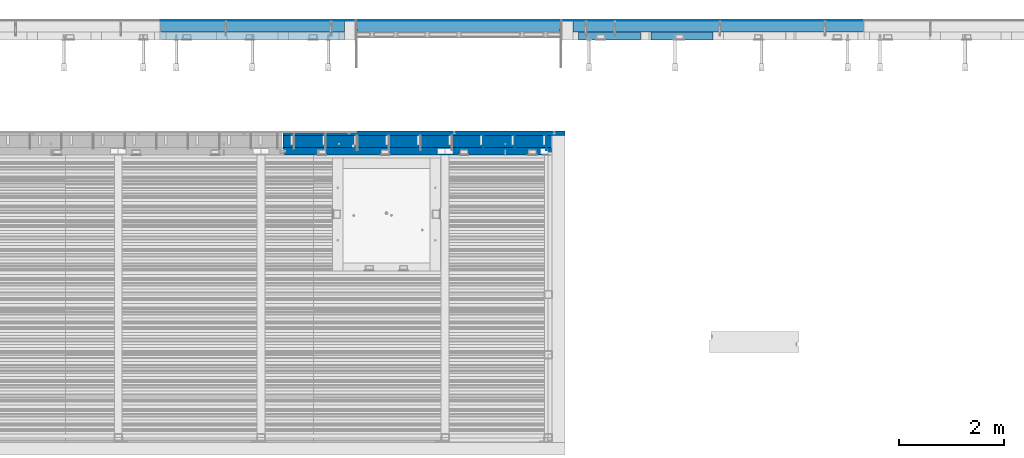
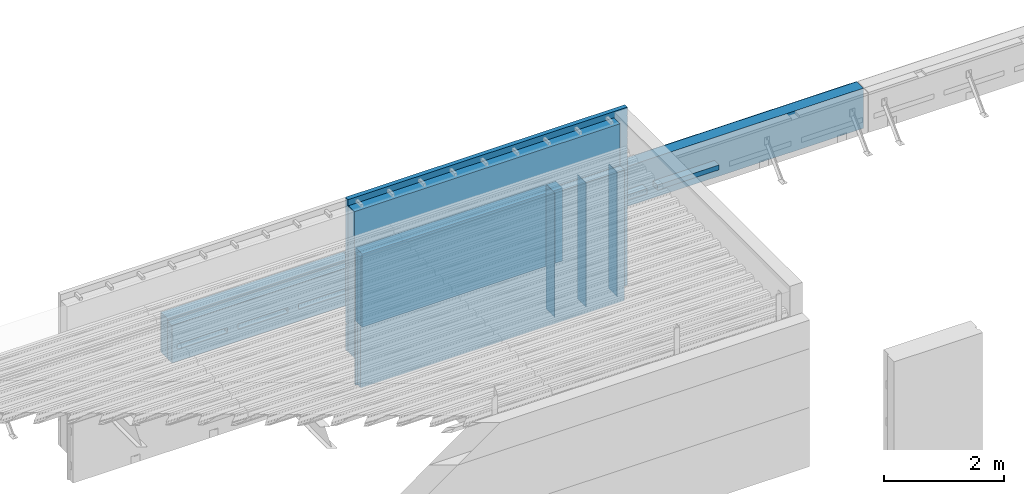
# One storey, part 80 of 153: 15 walls, 7 elements without a shape of their own.
"""IFC2X3 building model written with IfcOpenShell, lengths in millimetres."""

from ifc_helpers import new_model, si_unit, frame, origin_with_axes, place, context, subcontext, project, spatial, faceted_brep, material, type_object, element, aggregate, save


model = new_model("IFC2X3")

# Units and contexts
model_context = context("Model", 3, precision=1e-05, world=origin_with_axes())
body_context = subcontext(model_context, "Body", "Model", "MODEL_VIEW")
ifc_project = project(units=[si_unit("LENGTHUNIT", "METRE", prefix="MILLI"), si_unit("AREAUNIT", "SQUARE_METRE"), si_unit("VOLUMEUNIT", "CUBIC_METRE"), si_unit("MASSUNIT", "GRAM", prefix="KILO"), si_unit("TIMEUNIT", "SECOND"), si_unit("PLANEANGLEUNIT", "RADIAN"), si_unit("SOLIDANGLEUNIT", "STERADIAN"), si_unit("THERMODYNAMICTEMPERATUREUNIT", "DEGREE_CELSIUS"), si_unit("LUMINOUSINTENSITYUNIT", "LUMEN")], contexts=[model_context])

# Site, building, storey
site_placement = place(None, origin_with_axes())
site = spatial("IfcSite", under=ifc_project, at=site_placement, CompositionType="ELEMENT")
building_placement = place(site_placement, origin_with_axes())
building = spatial("IfcBuilding", under=site, at=building_placement, CompositionType="ELEMENT")
storey_placement = place(building_placement, origin_with_axes())
storey = spatial("IfcBuildingStorey", under=building, at=storey_placement, Name="8", CompositionType="ELEMENT", Elevation=0.0)

# Assembly, walls
assembly_1_placement = place(storey_placement, origin_with_axes())
assembly_1 = element("IfcElementAssembly", 1, at=assembly_1_placement, inside=storey, AssemblyPlace="NOTDEFINED", PredefinedType="REINFORCEMENT_UNIT")
ifc_material_1 = material(Name="Undefined")
wall_type_1 = type_object("IfcWallType", PredefinedType="NOTDEFINED")
wall_1_placement = place(assembly_1_placement, frame((21680.0500042038, 20799.9500000001, 104075.0), z_axis=(0.0, 0.0, 1.0), x_axis=(0.0, -1.0, 0.0)))
wall_1 = element("IfcWall", 2, at=wall_1_placement, type_object=wall_type_1, material=ifc_material_1, Name="(PD)", context=body_context, shape_type="Brep", body=[
    faceted_brep([(0.0, 5.0, -1265.0), (0.0, 5.0, 1265.0), (280.000000000011, 5.0, 1265.0), (280.000000000011, 5.0, -1265.0), (0.0, -5.0, 1265.0), (280.000000000011, -5.0, 1265.0), (0.0, -5.0, -1265.0), (280.000000000011, -5.0, -1265.0)], [[[0, 1, 2, 3]], [[1, 4, 5, 2]], [[4, 6, 7, 5]], [[6, 0, 3, 7]], [[5, 7, 3, 2]], [[6, 4, 1, 0]]]),
])
wall_2_placement = place(assembly_1_placement, frame((21080.0500042038, 20799.9500000001, 104075.0), z_axis=(0.0, 0.0, 1.0), x_axis=(0.0, -1.0, 0.0)))
wall_2 = element("IfcWall", 3, at=wall_2_placement, type_object=wall_type_1, material=ifc_material_1, Name="(PD)", context=body_context, shape_type="Brep", body=[
    faceted_brep([(0.0, 5.0, -1265.0), (0.0, 5.0, 1265.0), (280.000000000011, 5.0, 1265.0), (280.000000000011, 5.0, -1265.0), (0.0, -5.0, 1265.0), (280.000000000011, -5.0, 1265.0), (0.0, -5.0, -1265.0), (280.000000000011, -5.0, -1265.0)], [[[0, 1, 2, 3]], [[1, 4, 5, 2]], [[4, 6, 7, 5]], [[6, 0, 3, 7]], [[5, 7, 3, 2]], [[6, 4, 1, 0]]]),
])
wall_3_placement = place(assembly_1_placement, frame((20480.0500042038, 20799.9500000001, 104075.0), z_axis=(0.0, 0.0, 1.0), x_axis=(0.0, -1.0, 0.0)))
wall_3 = element("IfcWall", 4, at=wall_3_placement, type_object=wall_type_1, material=ifc_material_1, Name="(PD)", context=body_context, shape_type="Brep", body=[
    faceted_brep([(0.0, 5.0, -1265.0), (0.0, 5.0, 1265.0), (280.000000000011, 5.0, 1265.0), (280.000000000011, 5.0, -1265.0), (0.0, -5.0, 1265.0), (280.000000000011, -5.0, 1265.0), (0.0, -5.0, -1265.0), (280.000000000011, -5.0, -1265.0)], [[[0, 1, 2, 3]], [[1, 4, 5, 2]], [[4, 6, 7, 5]], [[6, 0, 3, 7]], [[5, 7, 3, 2]], [[6, 4, 1, 0]]]),
])

# Assemblies, wall
assembly_2_placement = place(storey_placement, origin_with_axes())
assembly_2 = element("IfcElementAssembly", 5, at=assembly_2_placement, inside=storey, AssemblyPlace="NOTDEFINED", PredefinedType="REINFORCEMENT_UNIT")
assembly_3_placement = place(assembly_2_placement, origin_with_axes())
assembly_3 = element("IfcElementAssembly", 6, at=assembly_3_placement, Name="Steel Assembly", AssemblyPlace="NOTDEFINED", PredefinedType="NOTDEFINED")
ifc_material_2 = material()
wall_type_2 = type_object("IfcWallType", PredefinedType="NOTDEFINED")
wall_4_placement = place(assembly_3_placement, frame((22185.0, 22880.0, 103162.5), z_axis=(0.0, 0.0, 1.0), x_axis=(1.0, 0.0, 0.0)))
wall_4 = element("IfcWall", 7, at=wall_4_placement, type_object=wall_type_2, material=ifc_material_2, context=body_context, shape_type="Brep", body=[
    faceted_brep([(0.0, 110.0, -407.5), (0.0, 110.0, 407.5), (5520.0, 110.0, 407.5), (5520.0, 110.0, -407.5), (0.0, -110.0, 407.5), (5520.0, -110.0, 407.5), (0.0, -110.0, -407.5), (5520.0, -110.0, -407.5)], [[[0, 1, 2, 3]], [[1, 4, 5, 2]], [[4, 6, 7, 5]], [[6, 0, 3, 7]], [[5, 7, 3, 2]], [[6, 4, 1, 0]]]),
])
aggregate(assembly_3, [wall_4])

assembly_4_placement = place(storey_placement, origin_with_axes())
assembly_4 = element("IfcElementAssembly", 8, at=assembly_4_placement, inside=storey, AssemblyPlace="NOTDEFINED", PredefinedType="REINFORCEMENT_UNIT")
assembly_5_placement = place(assembly_4_placement, origin_with_axes())
assembly_5 = element("IfcElementAssembly", 9, at=assembly_5_placement, Name="Steel Assembly", AssemblyPlace="NOTDEFINED", PredefinedType="NOTDEFINED")
wall_5_placement = place(assembly_5_placement, frame((14340.0, 22880.0, 103162.5), z_axis=(0.0, 0.0, 1.0), x_axis=(1.0, 0.0, 0.0)))
wall_5 = element("IfcWall", 10, at=wall_5_placement, type_object=wall_type_2, material=ifc_material_2, context=body_context, shape_type="Brep", body=[
    faceted_brep([(0.0, 110.0, -407.5), (0.0, 110.0, 407.5), (3495.0, 110.0, 407.5), (3495.0, 110.0, -407.5), (0.0, -110.0, 407.5), (3495.0, -110.0, 407.5), (0.0, -110.0, -407.5), (3495.0, -110.0, -407.5)], [[[0, 1, 2, 3]], [[1, 4, 5, 2]], [[4, 6, 7, 5]], [[6, 0, 3, 7]], [[5, 7, 3, 2]], [[6, 4, 1, 0]]]),
])
aggregate(assembly_5, [wall_5])

# Wall
ifc_material_3 = material()
wall_type_3 = type_object("IfcWallType", PredefinedType="NOTDEFINED")
wall_6_placement = place(assembly_2_placement, frame((21955.0, 22995.0, 103162.5), z_axis=(0.0, 0.0, 1.0), x_axis=(1.0, 0.0, 0.0)))
wall_6 = element("IfcWall", 11, at=wall_6_placement, type_object=wall_type_3, material=ifc_material_3, context=body_context, shape_type="Brep", body=[
    faceted_brep([(5750.0, -5.0, 407.5), (5750.0, -5.0, -407.5), (5750.0, 5.0, -407.5), (5750.0, 5.0, 407.5), (10.0, -5.0, 407.5), (10.0, -5.0, -407.5), (0.0, 5.0, -407.5), (0.0, 5.0, 407.5)], [[[0, 1, 2, 3]], [[1, 0, 4, 5]], [[2, 1, 5, 6]], [[3, 2, 6, 7]], [[0, 3, 7, 4]], [[5, 4, 7, 6]]]),
])

wall_7_placement = place(assembly_4_placement, frame((14340.0, 22995.0, 103162.5), z_axis=(0.0, 0.0, 1.0), x_axis=(1.0, 0.0, 0.0)))
wall_7 = element("IfcWall", 12, at=wall_7_placement, type_object=wall_type_3, material=ifc_material_3, context=body_context, shape_type="Brep", body=[
    faceted_brep([(0.0, -5.0, -407.5), (0.0, -5.0, 407.5), (0.0, 5.0, 407.5), (0.0, 5.0, -407.5), (3725.0, 5.0, 407.5), (3725.0, 5.0, -407.5), (3715.0, -5.0, -407.5), (3715.0, -5.0, 407.5)], [[[0, 1, 2, 3]], [[3, 2, 4, 5]], [[0, 3, 5, 6]], [[1, 0, 6, 7]], [[2, 1, 7, 4]], [[6, 5, 4, 7]]]),
])

ifc_material_4 = material(Name="EPS")
wall_type_4 = type_object("IfcWallType", PredefinedType="NOTDEFINED")
wall_8_placement = place(assembly_2_placement, frame((23665.0, 22695.0, 103055.0), z_axis=(0.0, 1.0, 0.0), x_axis=(1.0, 0.0, 0.0)))
wall_8 = element("IfcWall", 13, at=wall_8_placement, type_object=wall_type_4, material=ifc_material_4, context=body_context, shape_type="Brep", body=[
    faceted_brep([(0.0, 50.0, -75.0), (0.0, 50.0, 75.0), (1180.0, 50.0, 75.0), (1180.0, 50.0, -75.0), (0.0, -50.0, 75.0), (1180.0, -50.0, 75.0), (0.0, -50.0, -75.0), (1180.0, -50.0, -75.0)], [[[0, 1, 2, 3]], [[1, 4, 5, 2]], [[4, 6, 7, 5]], [[6, 0, 3, 7]], [[5, 7, 3, 2]], [[6, 4, 1, 0]]]),
])

wall_9_placement = place(assembly_2_placement, frame((22285.0, 22695.0, 103055.0), z_axis=(0.0, 1.0, 0.0), x_axis=(1.0, 0.0, 0.0)))
wall_9 = element("IfcWall", 14, at=wall_9_placement, type_object=wall_type_4, material=ifc_material_4, context=body_context, shape_type="Brep", body=[
    faceted_brep([(0.0, 50.0, -75.0), (0.0, 50.0, 75.0), (1180.0, 50.0, 75.0), (1180.0, 50.0, -75.0), (0.0, -50.0, 75.0), (1180.0, -50.0, 75.0), (0.0, -50.0, -75.0), (1180.0, -50.0, -75.0)], [[[0, 1, 2, 3]], [[1, 4, 5, 2]], [[4, 6, 7, 5]], [[6, 0, 3, 7]], [[5, 7, 3, 2]], [[6, 4, 1, 0]]]),
])

aggregate(assembly_2, [wall_8, wall_9, wall_6, assembly_3])

# Assembly, wall
assembly_6_placement = place(storey_placement, origin_with_axes())
assembly_6 = element("IfcElementAssembly", 15, at=assembly_6_placement, inside=storey, AssemblyPlace="NOTDEFINED", PredefinedType="REINFORCEMENT_UNIT")
ifc_material_5 = material(Name="CONCRETE/C30/37")
wall_type_5 = type_object("IfcWallType", PredefinedType="NOTDEFINED")
wall_10_placement = place(assembly_6_placement, frame((18080.0, 22995.0, 102827.5), z_axis=(0.0, 0.0, 1.0), x_axis=(1.0, 0.0, 0.0)))
wall_10 = element("IfcWall", 16, at=wall_10_placement, type_object=wall_type_5, material=ifc_material_5, context=body_context, shape_type="Brep", body=[
    faceted_brep([(0.0, 5.0, -742.5), (0.0, 5.0, 742.5), (3850.0, 5.0, 742.5), (3850.0, 5.0, -742.5), (0.0, -5.0, 742.5), (3850.0, -5.0, 742.5), (0.0, -5.0, -742.5), (3850.0, -5.0, -742.5)], [[[0, 1, 2, 3]], [[1, 4, 5, 2]], [[4, 6, 7, 5]], [[6, 0, 3, 7]], [[5, 7, 3, 2]], [[6, 4, 1, 0]]]),
])
aggregate(assembly_6, [wall_10])

assembly_7_placement = place(storey_placement, origin_with_axes())
assembly_7 = element("IfcElementAssembly", 17, at=assembly_7_placement, inside=storey, Name="Steel Assembly", AssemblyPlace="NOTDEFINED", PredefinedType="NOTDEFINED")
wall_type_6 = type_object("IfcWallType", PredefinedType="NOTDEFINED")
wall_11_placement = place(assembly_7_placement, frame((18080.0, 22880.0, 102827.5), z_axis=(0.0, 0.0, 1.0), x_axis=(1.0, 0.0, 0.0)))
wall_11 = element("IfcWall", 18, at=wall_11_placement, type_object=wall_type_6, material=ifc_material_3, context=body_context, shape_type="Brep", body=[
    faceted_brep([(0.0, 110.0, -742.5), (0.0, 110.0, 742.5), (3850.0, 110.0, 742.5), (3850.0, 110.0, -742.5), (0.0, -110.0, 742.5), (3850.0, -110.0, 742.5), (0.0, -110.0, -742.5), (3850.0, -110.0, -742.5)], [[[0, 1, 2, 3]], [[1, 4, 5, 2]], [[4, 6, 7, 5]], [[6, 0, 3, 7]], [[5, 7, 3, 2]], [[6, 4, 1, 0]]]),
])
aggregate(assembly_7, [wall_11])

# Wall
ifc_material_6 = material(Name="CONCRETE/C25/30")
wall_type_7 = type_object("IfcWallType", PredefinedType="NOTDEFINED")
wall_12_placement = place(assembly_1_placement, frame((16667.5, 20505.0, 104082.5), z_axis=(0.0, 0.0, 1.0), x_axis=(1.0, 0.0, 0.0)))
wall_12 = element("IfcWall", 19, at=wall_12_placement, type_object=wall_type_7, material=ifc_material_6, context=body_context, shape_type="Brep", body=[
    faceted_brep([(29.9999989349526, 25.0000007100352, 1327.5), (29.9999989349526, 25.0000007100352, -1327.5), (30.0000010509684, -75.0, -1327.5), (30.0000010509684, -75.0, 1327.5), (0.0, 45.0, 1327.5), (0.0, 45.0, -1327.5), (0.0, 75.0, -1327.5), (0.0, 75.0, 1327.5), (5102.5, 75.0, 1327.5), (5102.5, 75.0, -1327.5), (5102.5, -75.0, 1327.5), (5102.5, -75.0, -1327.5)], [[[0, 1, 2, 3]], [[4, 5, 1, 0]], [[6, 7, 8, 9]], [[10, 11, 9, 8]], [[11, 10, 3, 2]], [[6, 9, 11, 2, 1, 5]], [[7, 6, 5, 4]], [[10, 8, 7, 4, 0, 3]]]),
])

ifc_material_7 = material(Name="COS5gt")
wall_type_8 = type_object("IfcWallType", PredefinedType="NOTDEFINED")
wall_13_placement = place(assembly_1_placement, frame((16667.5, 20690.0, 104505.0), z_axis=(0.0, 0.0, 1.0), x_axis=(1.0, 0.0, 0.0)))
wall_13 = element("IfcWall", 20, at=wall_13_placement, type_object=wall_type_8, material=ifc_material_7, context=body_context, shape_type="Brep", body=[
    faceted_brep([(1309.99999999998, -110.0, -1050.0), (1309.99999999998, -60.0, -1050.0), (1359.99999999998, -60.0, -1050.0), (1359.99999999998, -110.0, -1050.0), (1310.0, -60.0, -1229.96997104255), (1310.0, -110.000001050059, -1229.96997114255), (1359.99999999998, -60.0, -1750.0), (1310.0, -60.0, -1750.0), (1359.99999999998, -110.0, -1750.0), (0.0, -110.0, 1750.0), (5102.5, -110.0, 1750.0), (5102.5, 90.0, 1750.0), (0.0, 90.0, 1750.0), (0.0, 90.0, 1700.0), (0.0, 110.0, 1700.0), (0.0, 110.0, -1229.96997070256), (0.0, -110.0, -1229.96997114255), (5102.5, 90.0, 1700.0), (5102.5, 110.0, 1700.0), (5102.5, 110.0, -1700.0), (1310.0, 110.0, -1700.0), (1310.0, 109.999998949941, -1229.96997070256), (5102.5, 90.0, -1700.0), (1310.0, 90.0, -1700.0), (5102.5, -110.0, -1750.0), (5102.5, 90.0, -1750.0), (1310.0, 90.0, -1750.0)], [[[0, 1, 2, 3]], [[4, 1, 0, 5]], [[6, 2, 1, 4, 7]], [[8, 3, 2, 6]], [[9, 10, 11, 12]], [[9, 12, 13, 14, 15, 16]], [[11, 17, 13, 12]], [[18, 14, 13, 17]], [[14, 18, 19, 20, 21, 15]], [[19, 22, 23, 20]], [[18, 17, 11, 10, 24, 25, 22, 19]], [[22, 25, 26, 23]], [[21, 20, 23, 26, 7, 4]], [[16, 15, 21, 4, 5]], [[24, 10, 9, 16, 5, 0, 3, 8]], [[26, 25, 24, 8, 6, 7]]]),
])

wall_type_9 = type_object("IfcWallType", PredefinedType="NOTDEFINED")
wall_14_placement = place(assembly_1_placement, frame((16667.5, 20842.5, 104557.5), z_axis=(0.0, 0.0, 1.0), x_axis=(1.0, 0.0, 0.0)))
wall_14 = element("IfcWall", 21, at=wall_14_placement, type_object=wall_type_9, material=ifc_material_5, context=body_context, shape_type="Brep", body=[
    faceted_brep([(5357.49999924993, 32.4999992499361, -1065.0000000008), (1400.0, 32.4999992499361, -1065.00000000077), (1400.0, 32.4999991119403, -1054.99999959956), (5357.49999911193, 32.4999991119403, -1054.99999959957), (5367.5, 42.4999994182217, -1067.00000005524), (1400.0, 42.4999992672783, -1067.00000005524), (1400.0, 42.4999992424127, -1053.00000011075), (5367.49999924239, 42.4999992424127, -1053.00000011075), (1400.0, 42.4999992423946, -1203.00000011075), (1400.0, 32.4999991119294, -1204.99999959957), (1400.0, 32.4999992499361, -1215.00000000079), (1400.0, 42.4999992672783, -1217.00000005524), (5367.49999924239, 42.4999992423946, -1203.00000011075), (5357.49999911193, 32.4999991119294, -1204.99999959957), (5357.49999924993, 32.4999992499361, -1215.00000000079), (5367.5, 42.5, -1217.00000005524), (1399.54, 32.4999992499361, -1665.00000000079), (1399.54, 32.4999991119294, -1654.99999959957), (5357.49999911193, 32.4999991119294, -1654.99999959957), (5357.49999924993, 32.4999992499361, -1665.00000000079), (1399.54, 42.4999992672783, -1667.00000005524), (5367.5, 42.5, -1667.00000005524), (1399.54, 42.4999992423946, -1653.00000011075), (5367.49999924239, 42.4999992423946, -1653.00000011075), (1399.54, 32.4999992499361, -1515.00000000079), (1399.54, 32.4999991119294, -1504.99999959957), (5357.49999911193, 32.4999991119294, -1504.99999959957), (5357.49999924993, 32.4999992499361, -1515.00000000079), (1399.54, 42.4999992672783, -1517.00000005524), (5367.5, 42.5, -1517.00000005524), (1399.54, 42.4999992423946, -1503.00000011075), (5367.49999924239, 42.4999992423946, -1503.00000011075), (1399.54, 32.4999992499361, -1365.00000000079), (1399.54, 32.4999991119294, -1354.99999959957), (5357.49999911193, 32.4999991119294, -1354.99999959957), (5357.49999924993, 32.4999992499361, -1365.00000000079), (1399.54, 42.4999992672783, -1367.00000005524), (5367.5, 42.5, -1367.00000005524), (1399.54, 42.4999992423946, -1353.00000011075), (5367.49999924239, 42.4999992423946, -1353.00000011075), (5367.5, -42.5, -1217.00000005524), (5367.5, -42.5, -1353.00000011075), (5357.49999911193, -42.5, -1354.99999959957), (5357.49999924993, -42.5, -1365.0000000008), (5367.5, -42.5, -1367.00000005524), (5367.5, -42.5, -1503.00000011075), (5357.49999911193, -42.5, -1504.99999959957), (5357.49999924993, -42.5, -1515.0000000008), (5367.5, -42.5, -1517.00000005524), (5367.5, -42.5, -1653.00000011075), (5357.49999911193, -42.5, -1654.99999959957), (5357.49999924993, -42.5, -1665.0000000008), (5367.5, -42.5, -1667.00000005524), (5367.5, -42.5, -1807.5), (5367.5, 42.5, -1807.5), (1310.0, -42.5, -1807.5), (1310.0, 42.5, -1807.5), (0.0, 42.5, -617.000000055239), (0.0, 32.4999992499324, -615.0000000008), (5357.49999924993, 32.4999992499324, -615.0000000008), (5367.5, 42.5, -617.000000055239), (3.63797880709171e-12, 32.4999992507037, -605.000000000742), (5357.49999911193, 32.4999991119257, -604.999999599575), (0.0, 42.5, -603.000000110755), (5367.49999924239, 42.4999992423946, -603.000000110755), (0.0, 42.5, -467.000000055239), (5367.5, 42.5, -467.000000055239), (0.0, 32.4999992499324, -465.0000000008), (5357.49999924993, 32.4999992499324, -465.0000000008), (0.0, 32.4999992507037, -455.000000000742), (5357.49999911193, 32.4999991119257, -454.999999599575), (0.0, 42.5, -453.000000110755), (5367.49999924239, 42.4999992423946, -453.000000110755), (0.0, 42.5, -317.000000055239), (5367.5, 42.5, -317.000000055239), (0.0, 32.4999992499324, -315.0000000008), (5357.49999924993, 32.4999992499324, -315.0000000008), (0.0, 32.4999992507037, -305.000000000742), (5357.49999911193, 32.4999991119257, -304.999999599575), (0.0, 42.5, -303.000000110755), (5367.49999924239, 42.4999992423946, -303.000000110755), (0.0, 42.5, -167.000000055239), (5367.5, 42.5, -167.000000055239), (0.0, 32.4999992499324, -165.0000000008), (5357.49999924993, 32.4999992499324, -165.0000000008), (3.63797880709171e-12, 32.4999992507037, -155.000000000742), (5357.49999911193, 32.4999991119257, -154.999999599575), (0.0, 42.5, -153.000000110755), (5367.49999924239, 42.4999992423946, -153.000000110755), (0.0, 42.5, -17.0000000552391), (5367.5, 42.5, -17.0000000552391), (0.0, 32.4999992499324, -15.0000000008004), (5357.49999924993, 32.4999992499324, -15.0000000008004), (0.0, 32.4999992507037, -5.00000000074215), (5357.49999911193, 32.4999991119257, -4.99999959957495), (0.0, 42.5, -3.00000011075463), (5367.49999924239, 42.4999992423946, -3.00000011075463), (0.0, 42.5, 132.999999944761), (5367.5, 42.5, 132.999999944761), (0.0, 32.4999992499324, 134.9999999992), (5357.49999924993, 32.4999992499324, 134.9999999992), (-3.63797880709171e-12, 32.4999992507037, 144.999999999258), (5357.49999911193, 32.4999991119257, 145.000000400425), (0.0, 42.5, 146.999999889245), (5367.49999924239, 42.4999992423946, 146.999999889245), (0.0, 42.5, 282.999999944761), (5367.5, 42.5, 282.999999944761), (0.0, 32.4999992499324, 284.9999999992), (5357.49999924993, 32.4999992499324, 284.9999999992), (-3.63797880709171e-12, 32.4999992507037, 294.999999999258), (5357.49999911193, 32.4999991119257, 295.000000400425), (0.0, 42.5, 296.999999889245), (5367.49999924239, 42.4999992423946, 296.999999889245), (0.0, 42.5, 432.999999944761), (5367.5, 42.5, 432.999999944761), (0.0, 32.4999992499324, 434.9999999992), (5357.49999924993, 32.4999992499324, 434.9999999992), (0.0, 32.4999992507037, 444.999999999258), (5357.49999911193, 32.4999991119257, 445.000000400425), (0.0, 42.5, 446.999999889245), (5367.49999924239, 42.4999992423946, 446.999999889245), (0.0, 42.5, 582.999999944761), (5367.5, 42.5, 582.999999944761), (0.0, 32.4999992499324, 584.9999999992), (5357.49999924993, 32.4999992499324, 584.9999999992), (3.63797880709171e-12, 32.4999992507037, 594.999999999258), (5357.49999911193, 32.4999991119257, 595.000000400425), (0.0, 42.5, 596.999999889245), (5367.49999924239, 42.4999992423946, 596.999999889245), (0.0, 42.5, 732.999999944761), (5367.5, 42.5, 732.999999944761), (0.0, 32.4999992499324, 734.9999999992), (5357.49999924993, 32.4999992499324, 734.9999999992), (0.0, 32.4999992507037, 744.999999999258), (5357.49999911193, 32.4999991119257, 745.000000400425), (0.0, 42.5, 746.999999889245), (5367.49999924239, 42.4999992423946, 746.999999889245), (0.0, 42.5, 882.999999944761), (5367.5, 42.5, 882.999999944761), (0.0, 32.4999992499324, 884.9999999992), (5357.49999924993, 32.4999992499324, 884.9999999992), (0.0, 32.4999992507037, 894.999999999258), (5357.49999911193, 32.4999991119257, 895.000000400425), (0.0, 42.5, 896.999999889245), (5367.49999924239, 42.4999992423946, 896.999999889245), (0.0, 42.5, 1032.99999994476), (5367.5, 42.5, 1032.99999994476), (0.0, 32.4999992499324, 1034.9999999992), (5357.49999924993, 32.4999992499324, 1034.9999999992), (0.0, 32.4999992507037, 1044.99999999926), (5357.49999911193, 32.4999991119257, 1045.00000040043), (0.0, 42.5, 1046.99999988925), (5367.49999924239, 42.4999992423946, 1046.99999988925), (0.0, 42.5, 1182.99999994476), (5367.5, 42.5, 1182.99999994476), (0.0, 32.4999992499324, 1184.9999999992), (5357.49999924993, 32.4999992499324, 1184.9999999992), (0.0, 32.4999992507037, 1194.99999999926), (5357.49999911193, 32.4999991119257, 1195.00000040043), (0.0, 42.5, 1196.99999988925), (5367.49999924239, 42.4999992423946, 1196.99999988925), (0.0, 42.5, 1332.99999994476), (5367.5, 42.5, 1332.99999994476), (0.0, 32.4999992499324, 1334.9999999992), (5357.49999924993, 32.4999992499324, 1334.9999999992), (-3.63797880709171e-12, 32.4999992507037, 1344.99999999926), (5357.49999911193, 32.4999991119257, 1345.00000040043), (0.0, 42.5, 1346.99999988925), (5367.49999924239, 42.4999992423946, 1346.99999988925), (0.0, 42.5, 1482.99999994476), (5367.5, 42.5, 1482.99999994476), (0.0, 32.4999992499324, 1484.9999999992), (5357.49999924993, 32.4999992499324, 1484.9999999992), (0.0, 32.4999992499361, 1494.99999999923), (5357.49999911193, 32.4999991119257, 1495.00000040043), (0.0, 42.5, 1496.99999988925), (5367.49999924239, 42.4999992423946, 1496.99999988925), (0.0, 42.5, 1632.99999994476), (5367.5, 42.5, 1632.99999994476), (0.0, 32.4999992499324, 1634.9999999992), (5357.49999924993, 32.4999992499324, 1634.9999999992), (0.0, 32.4999992499361, 1644.99999999923), (5357.49999911193, 32.4999991119257, 1645.00000040043), (0.0, 42.5, 1646.99999988925), (5367.49999924239, 42.4999992423946, 1646.99999988925), (0.0, 42.5, 1807.5), (5367.5, 42.5, 1807.5), (0.0, -42.5, 1807.5), (5367.5, -42.5, 1807.5), (5367.5, -42.5, 1646.99999988925), (5357.49999911193, -42.5, 1645.00000040043), (5357.49999924993, -42.5, 1634.9999999992), (5367.5, -42.5, 1632.99999994476), (5367.5, -42.5, 1496.99999988925), (5357.49999911193, -42.5, 1495.00000040043), (5357.49999924993, -42.5, 1484.9999999992), (5367.5, -42.5, 1482.99999994476), (5367.5, -42.5, 1346.99999988925), (5357.49999911193, -42.5, 1345.00000040043), (5357.49999924993, -42.5, 1334.9999999992), (5367.5, -42.5, 1332.99999994476), (5367.5, -42.5, 1196.99999988925), (5357.49999911193, -42.5, 1195.00000040043), (5357.49999924993, -42.5, 1184.9999999992), (5367.5, -42.5, 1182.99999994476), (5367.5, -42.5, 1046.99999988925), (5357.49999911193, -42.5, 1045.00000040043), (5357.49999924993, -42.5, 1034.9999999992), (5367.5, -42.5, 1032.99999994476), (5367.5, -42.5, 896.999999889245), (5357.49999911193, -42.5, 895.000000400425), (5357.49999924993, -42.5, 884.9999999992), (5367.5, -42.5, 882.999999944761), (5367.5, -42.5, 746.999999889245), (5357.49999911193, -42.5, 745.000000400425), (5357.49999924993, -42.5, 734.9999999992), (5367.5, -42.5, 732.999999944761), (5367.5, -42.5, 596.999999889245), (5357.49999911193, -42.5, 595.000000400425), (5357.49999924993, -42.5, 584.9999999992), (5367.5, -42.5, 582.999999944761), (5367.5, -42.5, 446.999999889245), (5357.49999911193, -42.5, 445.000000400425), (5357.49999924993, -42.5, 434.9999999992), (5367.5, -42.5, 432.999999944761), (5367.5, -42.5, 296.999999889245), (5357.49999911193, -42.5, 295.000000400425), (5357.49999924993, -42.5, 284.9999999992), (5367.5, -42.5, 282.999999944761), (5367.5, -42.5, 146.999999889245), (5357.49999911193, -42.5, 145.000000400425), (5357.49999924993, -42.5, 134.9999999992), (5367.5, -42.5, 132.999999944761), (5367.5, -42.5, -3.00000011075463), (5357.49999911193, -42.5, -4.99999959957495), (5357.49999924993, -42.5, -15.0000000008004), (5367.5, -42.5, -17.0000000552391), (5367.5, -42.5, -153.000000110755), (5357.49999911193, -42.5, -154.999999599575), (5357.49999924993, -42.5, -165.0000000008), (5367.5, -42.5, -167.000000055239), (5367.5, -42.5, -303.000000110755), (5357.49999911193, -42.5, -304.999999599575), (5357.49999924993, -42.5, -315.0000000008), (5367.5, -42.5, -317.000000055239), (5367.5, -42.5, -453.000000110755), (5357.49999911193, -42.5, -454.999999599575), (5357.49999924993, -42.5, -465.0000000008), (5367.5, -42.5, -467.000000055239), (5367.5, -42.5, -603.000000110755), (5357.49999911193, -42.5, -604.999999599575), (5357.49999924993, -42.5, -615.0000000008), (5367.5, -42.5, -617.000000055239), (5367.5, -42.5, -753.000000110755), (5367.49999924239, 42.4999998241728, -753.000000110755), (5365.0, 42.4999992672783, -767.000000055239), (5365.0, 39.9999999999563, -766.500000189029), (5365.0, 42.4999992663907, -766.500000189029), (5357.49999924993, 32.4999992499361, -765.000000000786), (1400.00000000001, 42.4999992672783, -767.000000055239), (1400.00000000001, 32.4999992499361, -765.000000000786), (5357.49999911193, 32.4999991119294, -754.999999599575), (1400.00000000001, 32.4999991119294, -754.999999599575), (5365.0, 42.4999992423946, -753.000000110755), (5365.0, 39.9999999999382, -753.499999824926), (1400.00000000001, 42.4999992423946, -753.000000110755), (5365.0, 42.4999992432822, -753.499999824926), (1400.00000000001, 42.4999999999854, -727.500000110711), (0.0, 42.5, -727.500000110711), (5357.49999911193, -42.5, -754.999999599575), (5357.49999924993, -42.5, -765.0000000008), (5367.5, 42.4999998060739, -767.000000055239), (5367.5, -42.5, -767.000000055239), (5367.5, -42.5, -903.000000110755), (5367.49999924239, 42.4999992424127, -903.000000110755), (5357.49999911193, -42.5, -904.999999599575), (5357.49999924993, -42.5, -915.0000000008), (5357.49999924993, 32.4999992499361, -915.0000000008), (5357.49999911193, 32.4999991119403, -904.999999599575), (1400.0, 42.4999992424127, -903.000000110755), (1400.0, 32.4999991119403, -904.99999959956), (1400.0, 32.4999992499361, -915.000000000771), (1400.0, 42.4999992672783, -917.000000055239), (5367.5, 42.4999996121478, -917.000000055239), (5367.5, -42.5, -917.000000055239), (5367.5, -42.5, -1053.00000011075), (1310.0, 42.4999995773069, -1282.46997070377), (0.0, 42.5, -1282.46997070377), (0.0, 42.5, -777.500000110711), (1400.00000000001, 42.4999999999854, -777.500000110711), (1400.00000000001, 12.4999999999854, -777.500000110711), (1400.00000000001, 12.4999999999854, -727.500000110711), (7.27595761418343e-12, 12.4999999999854, -777.500000110711), (7.27595761418343e-12, 12.4999999999854, -727.500000110711), (0.0, -42.5, -1282.46997087376), (1310.0, -42.5, -1282.46997087376), (5357.49999924993, -42.5, -1215.0000000008), (5357.49999911193, -42.5, -1204.99999959957), (5367.5, -42.5, -1203.00000011075), (5367.5, -42.5, -1067.00000005524), (5357.49999924993, -42.5, -1065.0000000008), (5357.49999911193, -42.5, -1054.99999959957)], [[[0, 1, 2, 3]], [[4, 5, 1, 0]], [[6, 2, 1, 5]], [[7, 3, 2, 6]], [[8, 9, 10, 11]], [[9, 8, 12, 13]], [[10, 9, 13, 14]], [[11, 10, 14, 15]], [[16, 17, 18, 19]], [[20, 16, 19, 21]], [[22, 17, 16, 20]], [[17, 22, 23, 18]], [[24, 25, 26, 27]], [[28, 24, 27, 29]], [[30, 25, 24, 28]], [[25, 30, 31, 26]], [[32, 33, 34, 35]], [[36, 32, 35, 37]], [[38, 33, 32, 36]], [[33, 38, 39, 34]], [[15, 40, 41, 39]], [[39, 41, 42, 34]], [[34, 42, 43, 35]], [[37, 35, 43, 44]], [[37, 44, 45, 31]], [[31, 45, 46, 26]], [[26, 46, 47, 27]], [[29, 27, 47, 48]], [[29, 48, 49, 23]], [[23, 49, 50, 18]], [[18, 50, 51, 19]], [[21, 19, 51, 52]], [[53, 54, 21, 52]], [[54, 53, 55, 56]], [[57, 58, 59, 60]], [[58, 61, 62, 59]], [[61, 63, 64, 62]], [[65, 66, 64, 63]], [[65, 67, 68, 66]], [[67, 69, 70, 68]], [[69, 71, 72, 70]], [[73, 74, 72, 71]], [[73, 75, 76, 74]], [[75, 77, 78, 76]], [[77, 79, 80, 78]], [[81, 82, 80, 79]], [[81, 83, 84, 82]], [[83, 85, 86, 84]], [[85, 87, 88, 86]], [[89, 90, 88, 87]], [[89, 91, 92, 90]], [[91, 93, 94, 92]], [[93, 95, 96, 94]], [[97, 98, 96, 95]], [[97, 99, 100, 98]], [[99, 101, 102, 100]], [[101, 103, 104, 102]], [[105, 106, 104, 103]], [[105, 107, 108, 106]], [[107, 109, 110, 108]], [[109, 111, 112, 110]], [[113, 114, 112, 111]], [[113, 115, 116, 114]], [[115, 117, 118, 116]], [[117, 119, 120, 118]], [[121, 122, 120, 119]], [[121, 123, 124, 122]], [[123, 125, 126, 124]], [[125, 127, 128, 126]], [[129, 130, 128, 127]], [[129, 131, 132, 130]], [[131, 133, 134, 132]], [[133, 135, 136, 134]], [[137, 138, 136, 135]], [[137, 139, 140, 138]], [[139, 141, 142, 140]], [[141, 143, 144, 142]], [[145, 146, 144, 143]], [[145, 147, 148, 146]], [[147, 149, 150, 148]], [[149, 151, 152, 150]], [[153, 154, 152, 151]], [[153, 155, 156, 154]], [[155, 157, 158, 156]], [[157, 159, 160, 158]], [[161, 162, 160, 159]], [[161, 163, 164, 162]], [[163, 165, 166, 164]], [[165, 167, 168, 166]], [[169, 170, 168, 167]], [[169, 171, 172, 170]], [[171, 173, 174, 172]], [[173, 175, 176, 174]], [[177, 178, 176, 175]], [[177, 179, 180, 178]], [[179, 181, 182, 180]], [[181, 183, 184, 182]], [[185, 186, 184, 183]], [[185, 187, 188, 186]], [[186, 188, 189, 184]], [[184, 189, 190, 182]], [[182, 190, 191, 180]], [[178, 180, 191, 192]], [[178, 192, 193, 176]], [[176, 193, 194, 174]], [[174, 194, 195, 172]], [[170, 172, 195, 196]], [[170, 196, 197, 168]], [[168, 197, 198, 166]], [[166, 198, 199, 164]], [[162, 164, 199, 200]], [[162, 200, 201, 160]], [[160, 201, 202, 158]], [[158, 202, 203, 156]], [[154, 156, 203, 204]], [[154, 204, 205, 152]], [[152, 205, 206, 150]], [[150, 206, 207, 148]], [[146, 148, 207, 208]], [[146, 208, 209, 144]], [[144, 209, 210, 142]], [[142, 210, 211, 140]], [[138, 140, 211, 212]], [[138, 212, 213, 136]], [[136, 213, 214, 134]], [[134, 214, 215, 132]], [[130, 132, 215, 216]], [[130, 216, 217, 128]], [[128, 217, 218, 126]], [[126, 218, 219, 124]], [[122, 124, 219, 220]], [[122, 220, 221, 120]], [[120, 221, 222, 118]], [[118, 222, 223, 116]], [[114, 116, 223, 224]], [[114, 224, 225, 112]], [[112, 225, 226, 110]], [[110, 226, 227, 108]], [[106, 108, 227, 228]], [[106, 228, 229, 104]], [[104, 229, 230, 102]], [[102, 230, 231, 100]], [[98, 100, 231, 232]], [[98, 232, 233, 96]], [[96, 233, 234, 94]], [[94, 234, 235, 92]], [[90, 92, 235, 236]], [[90, 236, 237, 88]], [[88, 237, 238, 86]], [[86, 238, 239, 84]], [[82, 84, 239, 240]], [[82, 240, 241, 80]], [[80, 241, 242, 78]], [[78, 242, 243, 76]], [[74, 76, 243, 244]], [[74, 244, 245, 72]], [[72, 245, 246, 70]], [[70, 246, 247, 68]], [[66, 68, 247, 248]], [[66, 248, 249, 64]], [[64, 249, 250, 62]], [[62, 250, 251, 59]], [[60, 59, 251, 252]], [[60, 252, 253, 254]], [[255, 256, 257]], [[258, 256, 255, 259, 260]], [[261, 258, 260, 262]], [[263, 264, 261, 262, 265]], [[57, 60, 254, 266, 263, 265, 267, 268]], [[263, 266, 264]], [[254, 253, 269, 261, 264, 266]], [[261, 269, 270, 258]], [[271, 257, 256, 258, 270, 272]], [[271, 272, 273, 274]], [[275, 276, 277, 278]], [[273, 275, 278, 274]], [[279, 280, 281, 282]], [[274, 278, 280, 279]], [[277, 281, 280, 278]], [[283, 282, 281, 277]], [[276, 284, 283, 277]], [[283, 284, 285, 7]], [[5, 4, 12, 8, 11, 15, 39, 38, 36, 37, 31, 30, 28, 29, 23, 22, 20, 21, 54, 56, 286, 287, 288, 289, 259, 255, 257, 271, 274, 279, 282, 283, 7, 6]], [[265, 262, 260, 259, 289, 290, 291, 267]], [[288, 292, 290, 289]], [[293, 291, 290, 292]], [[267, 291, 293, 268]], [[292, 288, 287, 294, 187, 185, 183, 181, 179, 177, 175, 173, 171, 169, 167, 165, 163, 161, 159, 157, 155, 153, 151, 149, 147, 145, 143, 141, 139, 137, 135, 133, 131, 129, 127, 125, 123, 121, 119, 117, 115, 113, 111, 109, 107, 105, 103, 101, 99, 97, 95, 93, 91, 89, 87, 85, 83, 81, 79, 77, 75, 73, 71, 69, 67, 65, 63, 61, 58, 57, 268, 293]], [[286, 295, 294, 287]], [[56, 55, 295, 286]], [[53, 52, 51, 50, 49, 48, 47, 46, 45, 44, 43, 42, 41, 40, 296, 297, 298, 299, 300, 301, 285, 284, 276, 275, 273, 272, 270, 269, 253, 252, 251, 250, 249, 248, 247, 246, 245, 244, 243, 242, 241, 240, 239, 238, 237, 236, 235, 234, 233, 232, 231, 230, 229, 228, 227, 226, 225, 224, 223, 222, 221, 220, 219, 218, 217, 216, 215, 214, 213, 212, 211, 210, 209, 208, 207, 206, 205, 204, 203, 202, 201, 200, 199, 198, 197, 196, 195, 194, 193, 192, 191, 190, 189, 188, 187, 294, 295, 55]], [[15, 14, 296, 40]], [[13, 297, 296, 14]], [[12, 298, 297, 13]], [[4, 299, 298, 12]], [[300, 299, 4, 0]], [[301, 300, 0, 3]], [[285, 301, 3, 7]]]),
])

aggregate(assembly_1, [wall_1, wall_2, wall_3, wall_12, wall_13, wall_14])

wall_type_10 = type_object("IfcWallType", PredefinedType="NOTDEFINED")
wall_15_placement = place(assembly_4_placement, frame((14340.0, 22695.0, 103137.5), z_axis=(0.0, 0.0, 1.0), x_axis=(1.0, 0.0, 0.0)))
wall_15 = element("IfcWall", 22, at=wall_15_placement, type_object=wall_type_10, material=ifc_material_6, context=body_context, shape_type="Brep", body=[
    faceted_brep([(2430.0, 75.0000000000073, -32.4999999999854), (2430.0, -74.9999999999927, -32.4999999999854), (2430.0, -74.9999999999927, -132.499999999985), (2430.0, 75.0000000000073, -132.499999999985), (3395.00000000001, -74.9999999999927, -132.499999999985), (3395.00000000001, 75.0000000000073, -132.499999999985), (3395.00000000001, -74.9999999999927, -32.4999999999854), (3395.00000000001, 75.0000000000073, -32.4999999999854), (-3.63797880709171e-12, 75.0000000000036, 382.5), (0.0, -75.0, 382.5), (3495.0, -75.0, 382.5), (3495.0, 75.0, 382.5), (0.0, -75.0, -382.5), (-3.63797880709171e-12, 75.0000000000036, -382.5), (3495.0, 75.0, -382.5), (3495.0, -75.0, -382.5), (1065.00000000001, 75.0000000000073, -132.499999999985), (1065.00000000001, -74.9999999999927, -132.499999999985), (1065.00000000001, -74.9999999999927, -32.4999999999854), (1065.00000000001, 75.0000000000073, -32.4999999999854), (100.000000000004, 74.9999999999818, -132.5), (99.999999984233, -75.0000345059671, -132.5), (100.000000000004, 74.9999999999818, -32.5), (99.999999984233, -75.0000345059671, -32.5), (1265.0, 75.0000000000073, -132.499999999985), (2230.00000000001, 75.0000000000073, -132.499999999985), (2230.00000000001, 75.0000000000073, -32.4999999999854), (1265.0, 75.0000000000073, -32.4999999999854), (1265.0, -74.9999999999927, -132.499999999985), (2230.00000000001, -74.9999999999927, -132.499999999985), (1265.0, -74.9999999999927, -32.4999999999854), (2230.00000000001, -74.9999999999927, -32.4999999999854)], [[[0, 1, 2, 3]], [[3, 2, 4, 5]], [[5, 4, 6, 7]], [[7, 6, 1, 0]], [[8, 9, 10, 11]], [[12, 9, 8, 13]], [[12, 13, 14, 15]], [[10, 15, 14, 11]], [[16, 17, 18, 19]], [[20, 21, 17, 16]], [[22, 23, 21, 20]], [[19, 18, 23, 22]], [[13, 8, 11, 14], [3, 5, 7, 0], [24, 25, 26, 27], [20, 16, 19, 22]], [[24, 28, 29, 25]], [[27, 30, 28, 24]], [[26, 31, 30, 27]], [[25, 29, 31, 26]], [[9, 12, 15, 10], [2, 1, 6, 4], [28, 30, 31, 29], [21, 23, 18, 17]]]),
])

aggregate(assembly_4, [wall_7, assembly_5, wall_15])

save(model, "model.ifc")
